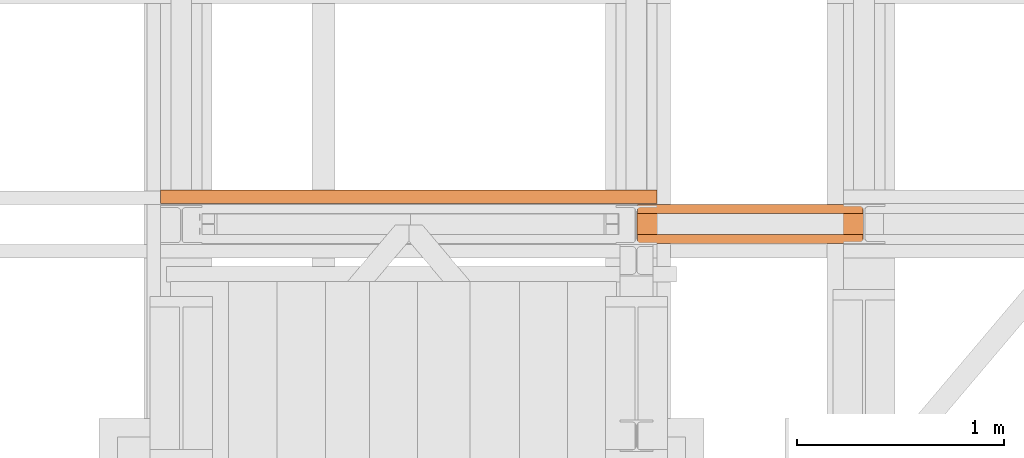
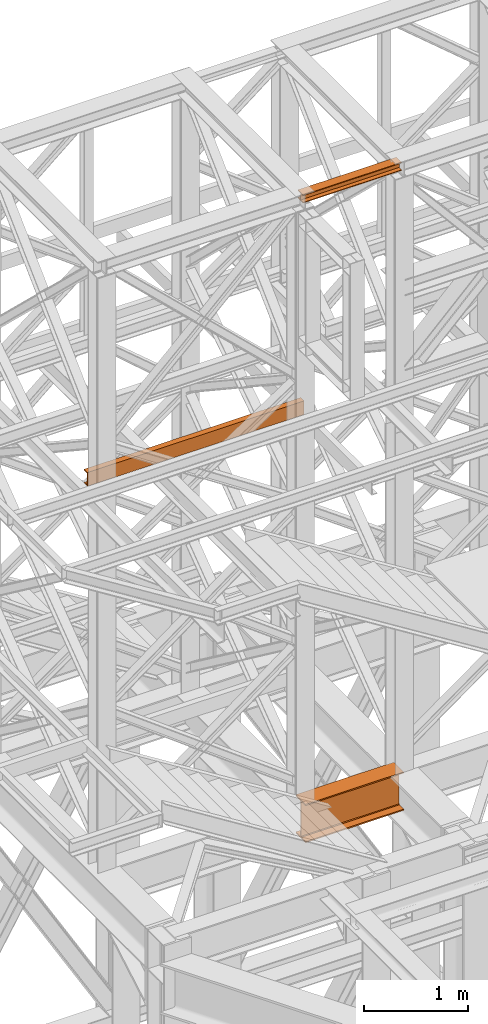
# One storey, part 90 of 208: 3 proxies.
"""IFC2X3 building model written with IfcOpenShell, lengths in millimetres."""

from ifc_helpers import new_model, entity, si_unit, converted_unit, frame, origin, origin_with_axes, place, context, subcontext, project, spatial, faceted_brep, element, save


model = new_model("IFC2X3")

# Units and contexts
model_context = context("Model", 3, precision=1e-05, world=origin())
plan_context = context("Plan", 3, precision=1e-05, world=origin())
body_context = subcontext(model_context, "Body", "Model", "MODEL_VIEW")
ifc_project = project(units=[si_unit("LENGTHUNIT", "METRE", prefix="MILLI"), converted_unit("PLANEANGLEUNIT", "DEGREE", entity("IfcPlaneAngleMeasure", 0.0174532925199433), si_unit("PLANEANGLEUNIT", "RADIAN"), dimensions=[0, 0, 0, 0, 0, 0, 0]), si_unit("AREAUNIT", "SQUARE_METRE"), si_unit("VOLUMEUNIT", "CUBIC_METRE")], contexts=[model_context, plan_context])

# Building, storey
building_placement = place(None, origin())
building = spatial("IfcBuilding", under=ifc_project, at=building_placement, CompositionType="COMPLEX")
storey_placement = place(building_placement, origin_with_axes())
storey = spatial("IfcBuildingStorey", under=building, at=storey_placement, Name="Geschoss", CompositionType="ELEMENT")

# Proxies
proxy_1_placement = place(storey_placement, frame((-1100.745031419179, -16057.57439657637, 4834.989987483023), z_axis=(0.0, 0.0, 1.0), x_axis=(1.0, 0.0, 0.0)))
element("IfcBuildingElementProxy", 1, at=proxy_1_placement, inside=storey, context=body_context, shape_type="Brep", body=[
    faceted_brep([(1088.009999895696, 0.01000000000021828, 450.0100178813937), (1088.009999895696, 190.0100125169756, 450.0100178813937), (1088.009999895696, 190.0100125169756, 435.4100240564349), (1088.009999895696, 120.7100073045494, 435.4100091552737), (1088.009999895696, 109.841562265754, 433.2347078418734), (1088.009999895696, 101.8853126263621, 425.2784563398363), (1088.009999895696, 99.71000619068764, 414.4100113010409), (1088.009999895696, 99.71000619068764, 35.60999167919181), (1088.009999895696, 101.8853126263621, 24.74154664039634), (1088.009999895696, 109.841562265754, 16.78529513835929), (1088.009999895696, 120.7100073045494, 14.60999382495902), (1088.009999895696, 190.0100125169756, 14.60999382495902), (1088.009999895696, 190.0100125169756, 0.01000000000021828), (1088.009999895696, 0.01000000000021828, 0.01000000000021828), (1088.009999895696, 0.01000000000021828, 14.60999382495902), (1088.009999895696, 69.3100052124264, 14.60999382495902), (1088.009999895696, 80.17845025122188, 16.78529513835929), (1088.009999895696, 88.13469989061377, 24.74154664039634), (1088.009999895696, 90.3100063262882, 35.60999167919181), (1088.009999895696, 90.3100063262882, 414.4100113010409), (1088.009999895696, 88.13469989061377, 425.2784563398363), (1088.009999895696, 80.17845025122188, 433.2347078418734), (1088.009999895696, 69.3100052124264, 435.4100091552737), (1088.009999895696, 0.01000000000021828, 435.4100240564349), (1088.009999895696, 190.0100125169756, 450.0100178813937), (1088.009999895696, 0.01000000000021828, 450.0100178813937), (0.009999999999990905, 0.01000000000021828, 450.0100178813937), (0.009999999999990905, 190.0100125169756, 450.0100178813937), (1088.009999895696, 190.0100125169756, 435.4100240564349), (1088.009999895696, 190.0100125169756, 450.0100178813937), (0.009999999999990905, 190.0100125169756, 450.0100178813937), (0.009999999999990905, 190.0100125169756, 435.4100240564349), (1088.009999895696, 120.7100073045494, 435.4100091552737), (1088.009999895696, 190.0100125169756, 435.4100240564349), (0.009999999999990905, 190.0100125169756, 435.4100240564349), (0.009999999999990905, 120.7100073045494, 435.4100091552737), (1088.009999895696, 109.841562265754, 433.2347078418734), (1088.009999895696, 120.7100073045494, 435.4100091552737), (0.009999999999990905, 120.7100073045494, 435.4100091552737), (0.009999999999990905, 109.841562265754, 433.2347078418734), (1088.009999895696, 101.8853126263621, 425.2784563398363), (1088.009999895696, 109.841562265754, 433.2347078418734), (0.009999999999990905, 109.841562265754, 433.2347078418734), (0.009999999999990905, 101.8853126263621, 425.2784563398363), (1088.009999895696, 99.71000619068764, 414.4100113010409), (1088.009999895696, 101.8853126263621, 425.2784563398363), (0.009999999999990905, 101.8853126263621, 425.2784563398363), (0.009999999999990905, 99.71000619068764, 414.4100113010409), (1088.009999895696, 99.71000619068764, 35.60999167919181), (1088.009999895696, 99.71000619068764, 414.4100113010409), (0.009999999999990905, 99.71000619068764, 414.4100113010409), (0.009999999999990905, 99.71000619068764, 35.60999167919181), (1088.009999895696, 101.8853126263621, 24.74154664039634), (1088.009999895696, 99.71000619068764, 35.60999167919181), (0.009999999999990905, 99.71000619068764, 35.60999167919181), (0.009999999999990905, 101.8853126263621, 24.74154664039634), (1088.009999895696, 109.841562265754, 16.78529513835929), (1088.009999895696, 101.8853126263621, 24.74154664039634), (0.009999999999990905, 101.8853126263621, 24.74154664039634), (0.009999999999990905, 109.841562265754, 16.78529513835929), (1088.009999895696, 120.7100073045494, 14.60999382495902), (1088.009999895696, 109.841562265754, 16.78529513835929), (0.009999999999990905, 109.841562265754, 16.78529513835929), (0.009999999999990905, 120.7100073045494, 14.60999382495902), (1088.009999895696, 190.0100125169756, 14.60999382495902), (1088.009999895696, 120.7100073045494, 14.60999382495902), (0.009999999999990905, 120.7100073045494, 14.60999382495902), (0.009999999999990905, 190.0100125169756, 14.60999382495902), (1088.009999895696, 190.0100125169756, 0.01000000000021828), (1088.009999895696, 190.0100125169756, 14.60999382495902), (0.009999999999990905, 190.0100125169756, 14.60999382495902), (0.009999999999990905, 190.0100125169756, 0.01000000000021828), (1088.009999895696, 0.01000000000021828, 0.01000000000021828), (1088.009999895696, 190.0100125169756, 0.01000000000021828), (0.009999999999990905, 190.0100125169756, 0.01000000000021828), (0.009999999999990905, 0.01000000000021828, 0.01000000000021828), (1088.009999895696, 0.01000000000021828, 14.60999382495902), (1088.009999895696, 0.01000000000021828, 0.01000000000021828), (0.009999999999990905, 0.01000000000021828, 0.01000000000021828), (0.009999999999990905, 0.01000000000021828, 14.60999382495902), (1088.009999895696, 69.3100052124264, 14.60999382495902), (1088.009999895696, 0.01000000000021828, 14.60999382495902), (0.009999999999990905, 0.01000000000021828, 14.60999382495902), (0.009999999999990905, 69.3100052124264, 14.60999382495902), (1088.009999895696, 80.17845025122188, 16.78529513835929), (1088.009999895696, 69.3100052124264, 14.60999382495902), (0.009999999999990905, 69.3100052124264, 14.60999382495902), (0.009999999999990905, 80.17845025122188, 16.78529513835929), (1088.009999895696, 88.13469989061377, 24.74154664039634), (1088.009999895696, 80.17845025122188, 16.78529513835929), (0.009999999999990905, 80.17845025122188, 16.78529513835929), (0.009999999999990905, 88.13469989061377, 24.74154664039634), (1088.009999895696, 90.3100063262882, 35.60999167919181), (1088.009999895696, 88.13469989061377, 24.74154664039634), (0.009999999999990905, 88.13469989061377, 24.74154664039634), (0.009999999999990905, 90.3100063262882, 35.60999167919181), (1088.009999895696, 90.3100063262882, 414.4100113010409), (1088.009999895696, 90.3100063262882, 35.60999167919181), (0.009999999999990905, 90.3100063262882, 35.60999167919181), (0.009999999999990905, 90.3100063262882, 414.4100113010409), (1088.009999895696, 88.13469989061377, 425.2784563398363), (1088.009999895696, 90.3100063262882, 414.4100113010409), (0.009999999999990905, 90.3100063262882, 414.4100113010409), (0.009999999999990905, 88.13469989061377, 425.2784563398363), (1088.009999895696, 80.17845025122188, 433.2347078418734), (1088.009999895696, 88.13469989061377, 425.2784563398363), (0.009999999999990905, 88.13469989061377, 425.2784563398363), (0.009999999999990905, 80.17845025122188, 433.2347078418734), (1088.009999895696, 69.3100052124264, 435.4100091552737), (1088.009999895696, 80.17845025122188, 433.2347078418734), (0.009999999999990905, 80.17845025122188, 433.2347078418734), (0.009999999999990905, 69.3100052124264, 435.4100091552737), (1088.009999895696, 0.01000000000021828, 435.4100240564349), (1088.009999895696, 69.3100052124264, 435.4100091552737), (0.009999999999990905, 69.3100052124264, 435.4100091552737), (0.009999999999990905, 0.01000000000021828, 435.4100240564349), (1088.009999895696, 0.01000000000021828, 450.0100178813937), (1088.009999895696, 0.01000000000021828, 435.4100240564349), (0.009999999999990905, 0.01000000000021828, 435.4100240564349), (0.009999999999990905, 0.01000000000021828, 450.0100178813937), (0.009999999999990905, 0.01000000000021828, 450.0100178813937), (0.009999999999990905, 0.01000000000021828, 435.4100240564349), (0.009999999999990905, 69.3100052124264, 435.4100091552737), (0.009999999999990905, 80.17845025122188, 433.2347078418734), (0.009999999999990905, 88.13469989061377, 425.2784563398363), (0.009999999999990905, 90.3100063262882, 414.4100113010409), (0.009999999999990905, 90.3100063262882, 35.60999167919181), (0.009999999999990905, 88.13469989061377, 24.74154664039634), (0.009999999999990905, 80.17845025122188, 16.78529513835929), (0.009999999999990905, 69.3100052124264, 14.60999382495902), (0.009999999999990905, 0.01000000000021828, 14.60999382495902), (0.009999999999990905, 0.01000000000021828, 0.01000000000021828), (0.009999999999990905, 190.0100125169756, 0.01000000000021828), (0.009999999999990905, 190.0100125169756, 14.60999382495902), (0.009999999999990905, 120.7100073045494, 14.60999382495902), (0.009999999999990905, 109.841562265754, 16.78529513835929), (0.009999999999990905, 101.8853126263621, 24.74154664039634), (0.009999999999990905, 99.71000619068764, 35.60999167919181), (0.009999999999990905, 99.71000619068764, 414.4100113010409), (0.009999999999990905, 101.8853126263621, 425.2784563398363), (0.009999999999990905, 109.841562265754, 433.2347078418734), (0.009999999999990905, 120.7100073045494, 435.4100091552737), (0.009999999999990905, 190.0100125169756, 435.4100240564349), (0.009999999999990905, 190.0100125169756, 450.0100178813937)], [[[0, 1, 2, 3, 4, 5, 6, 7, 8, 9, 10, 11, 12, 13, 14, 15, 16, 17, 18, 19, 20, 21, 22, 23]], [[24, 25, 26, 27]], [[28, 29, 30, 31]], [[32, 33, 34, 35]], [[36, 37, 38, 39]], [[40, 41, 42, 43]], [[44, 45, 46, 47]], [[48, 49, 50, 51]], [[52, 53, 54, 55]], [[56, 57, 58, 59]], [[60, 61, 62, 63]], [[64, 65, 66, 67]], [[68, 69, 70, 71]], [[72, 73, 74, 75]], [[76, 77, 78, 79]], [[80, 81, 82, 83]], [[84, 85, 86, 87]], [[88, 89, 90, 91]], [[92, 93, 94, 95]], [[96, 97, 98, 99]], [[100, 101, 102, 103]], [[104, 105, 106, 107]], [[108, 109, 110, 111]], [[112, 113, 114, 115]], [[116, 117, 118, 119]], [[120, 121, 122, 123, 124, 125, 126, 127, 128, 129, 130, 131, 132, 133, 134, 135, 136, 137, 138, 139, 140, 141, 142, 143]]], orient=[[False], [False], [False], [False], [False], [False], [False], [False], [False], [False], [False], [False], [False], [False], [False], [False], [False], [False], [False], [False], [False], [False], [False], [False], [False], [False]]),
])
proxy_2_placement = place(storey_placement, frame((-1103.495031404279, -16012.50587051043, 12300.47045114381), z_axis=(0.0, 0.0, 1.0), x_axis=(1.0, 0.0, 0.0)))
element("IfcBuildingElementProxy", 2, at=proxy_2_placement, inside=storey, context=body_context, shape_type="Brep", body=[
    faceted_brep([(1093.509999865889, 0.01000000000021828, 88.01000000000022), (1093.509999865889, 0.01000000000021828, 96.01000000000022), (1093.509999865889, 100.0100000000002, 96.01000000000022), (1093.509999865889, 100.0100000000002, 88.01000000000022), (1093.509999865889, 52.51000000000022, 88.01000000000022), (1093.509999865889, 52.51000000000022, 8.010000000000218), (1093.509999865889, 100.0100000000002, 8.010000000000218), (1093.509999865889, 100.0100000000002, 0.01000000000021828), (1093.509999865889, 0.01000000000021828, 0.01000000000021828), (1093.509999865889, 0.01000000000021828, 8.010000000000218), (1093.509999865889, 47.51000000000022, 8.010000000000218), (1093.509999865889, 47.51000000000022, 88.01000000000022), (1093.509999865889, 0.01000000000021828, 96.01000000000022), (1093.509999865889, 0.01000000000021828, 88.01000000000022), (0.009999999999990905, 0.01000000000385626, 88.01000000000022), (0.009999999999990905, 0.01000000000385626, 96.01000000000022), (1093.509999865889, 100.0100000000002, 96.01000000000022), (1093.509999865889, 0.01000000000021828, 96.01000000000022), (0.009999999999990905, 0.01000000000385626, 96.01000000000022), (0.009999999999990905, 100.0100000000039, 96.01000000000022), (1093.509999865889, 100.0100000000002, 88.01000000000022), (1093.509999865889, 100.0100000000002, 96.01000000000022), (0.009999999999990905, 100.0100000000039, 96.01000000000022), (0.009999999999990905, 100.0100000000039, 88.01000000000022), (1093.509999865889, 52.51000000000022, 88.01000000000022), (1093.509999865889, 100.0100000000002, 88.01000000000022), (0.009999999999990905, 100.0100000000039, 88.01000000000022), (0.009999999999990905, 52.51000000000386, 88.01000000000022), (1093.509999865889, 52.51000000000022, 8.010000000000218), (1093.509999865889, 52.51000000000022, 88.01000000000022), (0.009999999999990905, 52.51000000000386, 88.01000000000022), (0.009999999999990905, 52.51000000000386, 8.010000000000218), (1093.509999865889, 100.0100000000002, 8.010000000000218), (1093.509999865889, 52.51000000000022, 8.010000000000218), (0.009999999999990905, 52.51000000000386, 8.010000000000218), (0.009999999999990905, 100.0100000000039, 8.010000000000218), (1093.509999865889, 100.0100000000002, 0.01000000000021828), (1093.509999865889, 100.0100000000002, 8.010000000000218), (0.009999999999990905, 100.0100000000039, 8.010000000000218), (0.009999999999990905, 100.0100000000039, 0.01000000000021828), (1093.509999865889, 0.01000000000021828, 0.01000000000021828), (1093.509999865889, 100.0100000000002, 0.01000000000021828), (0.009999999999990905, 100.0100000000039, 0.01000000000021828), (0.009999999999990905, 0.01000000000385626, 0.01000000000021828), (1093.509999865889, 0.01000000000021828, 8.010000000000218), (1093.509999865889, 0.01000000000021828, 0.01000000000021828), (0.009999999999990905, 0.01000000000385626, 0.01000000000021828), (0.009999999999990905, 0.01000000000385626, 8.010000000000218), (1093.509999865889, 47.51000000000022, 8.010000000000218), (1093.509999865889, 0.01000000000021828, 8.010000000000218), (0.009999999999990905, 0.01000000000385626, 8.010000000000218), (0.009999999999990905, 47.51000000000386, 8.010000000000218), (1093.509999865889, 47.51000000000022, 88.01000000000022), (1093.509999865889, 47.51000000000022, 8.010000000000218), (0.009999999999990905, 47.51000000000386, 8.010000000000218), (0.009999999999990905, 47.51000000000386, 88.01000000000022), (1093.509999865889, 0.01000000000021828, 88.01000000000022), (1093.509999865889, 47.51000000000022, 88.01000000000022), (0.009999999999990905, 47.51000000000386, 88.01000000000022), (0.009999999999990905, 0.01000000000385626, 88.01000000000022), (0.009999999999990905, 0.01000000000385626, 88.01000000000022), (0.009999999999990905, 47.51000000000386, 88.01000000000022), (0.009999999999990905, 47.51000000000386, 8.010000000000218), (0.009999999999990905, 0.01000000000385626, 8.010000000000218), (0.009999999999990905, 0.01000000000385626, 0.01000000000021828), (0.009999999999990905, 100.0100000000039, 0.01000000000021828), (0.009999999999990905, 100.0100000000039, 8.010000000000218), (0.009999999999990905, 52.51000000000386, 8.010000000000218), (0.009999999999990905, 52.51000000000386, 88.01000000000022), (0.009999999999990905, 100.0100000000039, 88.01000000000022), (0.009999999999990905, 100.0100000000039, 96.01000000000022), (0.009999999999990905, 0.01000000000385626, 96.01000000000022)], [[[0, 1, 2, 3, 4, 5, 6, 7, 8, 9, 10, 11]], [[12, 13, 14, 15]], [[16, 17, 18, 19]], [[20, 21, 22, 23]], [[24, 25, 26, 27]], [[28, 29, 30, 31]], [[32, 33, 34, 35]], [[36, 37, 38, 39]], [[40, 41, 42, 43]], [[44, 45, 46, 47]], [[48, 49, 50, 51]], [[52, 53, 54, 55]], [[56, 57, 58, 59]], [[60, 61, 62, 63, 64, 65, 66, 67, 68, 69, 70, 71]]], orient=[[False], [False], [False], [False], [False], [False], [False], [False], [False], [False], [False], [False], [False], [False]]),
])
proxy_3_placement = place(storey_placement, frame((-3406.561117037341, -15862.57605638884, 9699.99), z_axis=(0.0, 0.0, 1.0), x_axis=(1.0, 0.0, 0.0)))
element("IfcBuildingElementProxy", 3, at=proxy_3_placement, inside=storey, context=body_context, shape_type="Brep", body=[
    faceted_brep([(0.01000000000021828, 65.01181901812197, 0.01000000000021828), (2399.826087056121, 65.01000000000022, 0.01000000000021828), (2399.826087056121, 65.01000000000022, 3.132428070246533), (0.01000000000021828, 65.01181901812197, 3.132428070246533), (0.01000000000021828, 65.01181901812197, 3.132428070246533), (2399.826087056121, 65.01000000000022, 3.132428070246533), (2399.826087056121, 64.76726342282564, 4.748288908171162), (0.01000000000021828, 64.7690824409492, 4.748288908171162), (0.01000000000021828, 64.7690824409492, 4.748288908171162), (2399.826087056121, 64.76726342282564, 4.748288908171162), (2399.826087056121, 64.06053228585552, 6.221534443444398), (0.01000000000021828, 64.06235130397909, 6.221534443444398), (0.01000000000021828, 64.06235130397909, 6.221534443444398), (2399.826087056121, 64.06053228585552, 6.221534443444398), (2399.826087056121, 62.95215163846842, 7.422126703873801), (0.01000000000021828, 62.95397065659199, 7.422126703873801), (0.01000000000021828, 62.95397065659199, 7.422126703873801), (2399.826087056121, 62.95215163846842, 7.422126703873801), (2399.826087056121, 61.53995641148504, 8.244091391710754), (0.01000000000021828, 61.54177542960679, 8.244091391710754), (0.01000000000021828, 61.54177542960679, 8.244091391710754), (2399.826087056121, 61.53995641148504, 8.244091391710754), (2399.826087056121, 59.9485987225562, 8.614912102195376), (0.01000000000021828, 59.95041774067795, 8.614912102195376), (0.01000000000021828, 59.95041774067795, 8.614912102195376), (2399.826087056121, 59.9485987225562, 8.614912102195376), (2399.826087056121, 17.17267516602988, 12.0369859867169), (0.01000000000021828, 17.17449418415163, 12.0369859867169), (0.01000000000021828, 17.17449418415163, 12.0369859867169), (2399.826087056121, 17.17267516602988, 12.0369859867169), (2399.826087056121, 14.13462866898408, 12.74491643400506), (0.01000000000021828, 14.13644768710583, 12.74491643400506), (0.01000000000021828, 14.13644768710583, 12.74491643400506), (2399.826087056121, 14.13462866898408, 12.74491643400506), (2399.826087056121, 11.43861959928654, 14.31412174714933), (0.01000000000021828, 11.44043861740829, 14.31412174714933), (0.01000000000021828, 11.44043861740829, 14.31412174714933), (2399.826087056121, 11.43861959928654, 14.31412174714933), (2399.826087056121, 9.322620181546881, 16.60616151705835), (0.01000000000021828, 9.324439199668632, 16.60616151705835), (0.01000000000021828, 9.324439199668632, 16.60616151705835), (2399.826087056121, 9.322620181546881, 16.60616151705835), (2399.826087056121, 7.973406192784751, 19.41872117530875), (0.01000000000021828, 7.97522521090832, 19.41872117530875), (0.01000000000021828, 7.97522521090832, 19.41872117530875), (2399.826087056121, 7.973406192784751, 19.41872117530875), (2399.826087056121, 7.510000000000218, 22.50354641134618), (0.01000000000021828, 7.511819018121969, 22.50354641134618), (0.01000000000021828, 7.511819018121969, 22.50354641134618), (2399.826087056121, 7.510000000000218, 22.50354641134618), (2399.826087056121, 7.510000000000218, 137.5164535886524), (0.01000000000021828, 7.511819018121969, 137.5164535886524), (0.01000000000021828, 7.511819018121969, 137.5164535886524), (2399.826087056121, 7.510000000000218, 137.5164535886524), (2399.826087056121, 7.973406192784751, 140.6012788246917), (0.01000000000021828, 7.97522521090832, 140.6012788246917), (0.01000000000021828, 7.97522521090832, 140.6012788246917), (2399.826087056121, 7.973406192784751, 140.6012788246917), (2399.826087056121, 9.322620181546881, 143.4138384829403), (0.01000000000021828, 9.324439199668632, 143.4138384829403), (0.01000000000021828, 9.324439199668632, 143.4138384829403), (2399.826087056121, 9.322620181546881, 143.4138384829403), (2399.826087056121, 11.43861959928654, 145.7058782528493), (0.01000000000021828, 11.44043861740829, 145.7058782528493), (0.01000000000021828, 11.44043861740829, 145.7058782528493), (2399.826087056121, 11.43861959928654, 145.7058782528493), (2399.826087056121, 14.13462866898408, 147.2750835659936), (0.01000000000021828, 14.13644768710583, 147.2750835659936), (0.01000000000021828, 14.13644768710583, 147.2750835659936), (2399.826087056121, 14.13462866898408, 147.2750835659936), (2399.826087056121, 17.17267516602988, 147.9830140132817), (0.01000000000021828, 17.17449418415163, 147.9830140132817), (0.01000000000021828, 17.17449418415163, 147.9830140132817), (2399.826087056121, 17.17267516602988, 147.9830140132817), (2399.826087056121, 59.9485987225562, 151.4050878978032), (0.01000000000021828, 59.95041774067795, 151.4050878978032), (0.01000000000021828, 59.95041774067795, 151.4050878978032), (2399.826087056121, 59.9485987225562, 151.4050878978032), (2399.826087056121, 61.53995641148504, 151.7759086082879), (0.01000000000021828, 61.54177542960679, 151.7759086082879), (0.01000000000021828, 61.54177542960679, 151.7759086082879), (2399.826087056121, 61.53995641148504, 151.7759086082879), (2399.826087056121, 62.95215163846842, 152.5978732961248), (0.01000000000021828, 62.95397065659199, 152.5978732961248), (0.01000000000021828, 62.95397065659199, 152.5978732961248), (2399.826087056121, 62.95215163846842, 152.5978732961248), (2399.826087056121, 64.06053228585552, 153.7984655565542), (0.01000000000021828, 64.06235130397909, 153.7984655565542), (0.01000000000021828, 64.06235130397909, 153.7984655565542), (2399.826087056121, 64.06053228585552, 153.7984655565542), (2399.826087056121, 64.76726342282564, 155.2717110918275), (0.01000000000021828, 64.7690824409492, 155.2717110918275), (0.01000000000021828, 64.7690824409492, 155.2717110918275), (2399.826087056121, 64.76726342282564, 155.2717110918275), (2399.826087056121, 65.01000000000022, 156.8875719297521), (0.01000000000021828, 65.01181901812197, 156.8875719297521), (0.01000000000021828, 65.01181901812197, 156.8875719297521), (2399.826087056121, 65.01000000000022, 156.8875719297521), (2399.826087056121, 65.01000000000022, 160.0100000000002), (0.01000000000021828, 65.01181901812197, 160.0100000000002), (0.01000000000021828, 65.01181901812197, 160.0100000000002), (2399.826087056121, 65.01000000000022, 160.0100000000002), (2399.826087056121, 0.01000000000021828, 160.0100000000002), (0.01000000000021828, 0.01181901812196884, 160.0100000000002), (0.01000000000021828, 0.01181901812196884, 160.0100000000002), (2399.826087056121, 0.01000000000021828, 160.0100000000002), (2399.826087056121, 0.01000000000021828, 0.01000000000021828), (0.01000000000021828, 0.01181901812196884, 0.01000000000021828), (0.01000000000021828, 0.01181901812196884, 0.01000000000021828), (2399.826087056121, 0.01000000000021828, 0.01000000000021828), (2399.826087056121, 65.01000000000022, 0.01000000000021828), (0.01000000000021828, 65.01181901812197, 0.01000000000021828), (0.01000000000021828, 65.01181901812197, 0.01000000000021828), (0.01000000000021828, 65.01181901812197, 3.132428070246533), (0.01000000000021828, 64.7690824409492, 4.748288908171162), (0.01000000000021828, 64.06235130397909, 6.221534443444398), (0.01000000000021828, 62.95397065659199, 7.422126703873801), (0.01000000000021828, 61.54177542960679, 8.244091391710754), (0.01000000000021828, 59.95041774067795, 8.614912102195376), (0.01000000000021828, 17.17449418415163, 12.0369859867169), (0.01000000000021828, 14.13644768710583, 12.74491643400506), (0.01000000000021828, 11.44043861740829, 14.31412174714933), (0.01000000000021828, 9.324439199668632, 16.60616151705835), (0.01000000000021828, 7.97522521090832, 19.41872117530875), (0.01000000000021828, 7.511819018121969, 22.50354641134618), (0.01000000000021828, 7.511819018121969, 137.5164535886524), (0.01000000000021828, 7.97522521090832, 140.6012788246917), (0.01000000000021828, 9.324439199668632, 143.4138384829403), (0.01000000000021828, 11.44043861740829, 145.7058782528493), (0.01000000000021828, 14.13644768710583, 147.2750835659936), (0.01000000000021828, 17.17449418415163, 147.9830140132817), (0.01000000000021828, 59.95041774067795, 151.4050878978032), (0.01000000000021828, 61.54177542960679, 151.7759086082879), (0.01000000000021828, 62.95397065659199, 152.5978732961248), (0.01000000000021828, 64.06235130397909, 153.7984655565542), (0.01000000000021828, 64.7690824409492, 155.2717110918275), (0.01000000000021828, 65.01181901812197, 156.8875719297521), (0.01000000000021828, 65.01181901812197, 160.0100000000002), (0.01000000000021828, 0.01181901812196884, 160.0100000000002), (0.01000000000021828, 0.01181901812196884, 0.01000000000021828), (2399.826087056121, 65.01000000000022, 0.01000000000021828), (2399.826087056121, 0.01000000000021828, 0.01000000000021828), (2399.826087056121, 0.01000000000021828, 160.0100000000002), (2399.826087056121, 65.01000000000022, 160.0100000000002), (2399.826087056121, 65.01000000000022, 156.8875719297521), (2399.826087056121, 64.76726342282564, 155.2717110918275), (2399.826087056121, 64.06053228585552, 153.7984655565542), (2399.826087056121, 62.95215163846842, 152.5978732961248), (2399.826087056121, 61.53995641148504, 151.7759086082879), (2399.826087056121, 59.9485987225562, 151.4050878978032), (2399.826087056121, 17.17267516602988, 147.9830140132817), (2399.826087056121, 14.13462866898408, 147.2750835659936), (2399.826087056121, 11.43861959928654, 145.7058782528493), (2399.826087056121, 9.322620181546881, 143.4138384829403), (2399.826087056121, 7.973406192784751, 140.6012788246917), (2399.826087056121, 7.510000000000218, 137.5164535886524), (2399.826087056121, 7.510000000000218, 22.50354641134618), (2399.826087056121, 7.973406192784751, 19.41872117530875), (2399.826087056121, 9.322620181546881, 16.60616151705835), (2399.826087056121, 11.43861959928654, 14.31412174714933), (2399.826087056121, 14.13462866898408, 12.74491643400506), (2399.826087056121, 17.17267516602988, 12.0369859867169), (2399.826087056121, 59.9485987225562, 8.614912102195376), (2399.826087056121, 61.53995641148504, 8.244091391710754), (2399.826087056121, 62.95215163846842, 7.422126703873801), (2399.826087056121, 64.06053228585552, 6.221534443444398), (2399.826087056121, 64.76726342282564, 4.748288908171162), (2399.826087056121, 65.01000000000022, 3.132428070246533)], [[[0, 1, 2, 3]], [[4, 5, 6, 7]], [[8, 9, 10, 11]], [[12, 13, 14, 15]], [[16, 17, 18, 19]], [[20, 21, 22, 23]], [[24, 25, 26, 27]], [[28, 29, 30, 31]], [[32, 33, 34, 35]], [[36, 37, 38, 39]], [[40, 41, 42, 43]], [[44, 45, 46, 47]], [[48, 49, 50, 51]], [[52, 53, 54, 55]], [[56, 57, 58, 59]], [[60, 61, 62, 63]], [[64, 65, 66, 67]], [[68, 69, 70, 71]], [[72, 73, 74, 75]], [[76, 77, 78, 79]], [[80, 81, 82, 83]], [[84, 85, 86, 87]], [[88, 89, 90, 91]], [[92, 93, 94, 95]], [[96, 97, 98, 99]], [[100, 101, 102, 103]], [[104, 105, 106, 107]], [[108, 109, 110, 111]], [[112, 113, 114, 115, 116, 117, 118, 119, 120, 121, 122, 123, 124, 125, 126, 127, 128, 129, 130, 131, 132, 133, 134, 135, 136, 137, 138, 139]], [[140, 141, 142, 143, 144, 145, 146, 147, 148, 149, 150, 151, 152, 153, 154, 155, 156, 157, 158, 159, 160, 161, 162, 163, 164, 165, 166, 167]]], orient=[[False], [False], [False], [False], [False], [False], [False], [False], [False], [False], [False], [False], [False], [False], [False], [False], [False], [False], [False], [False], [False], [False], [False], [False], [False], [False], [False], [False], [False], [False]]),
])

save(model, "model.ifc")
